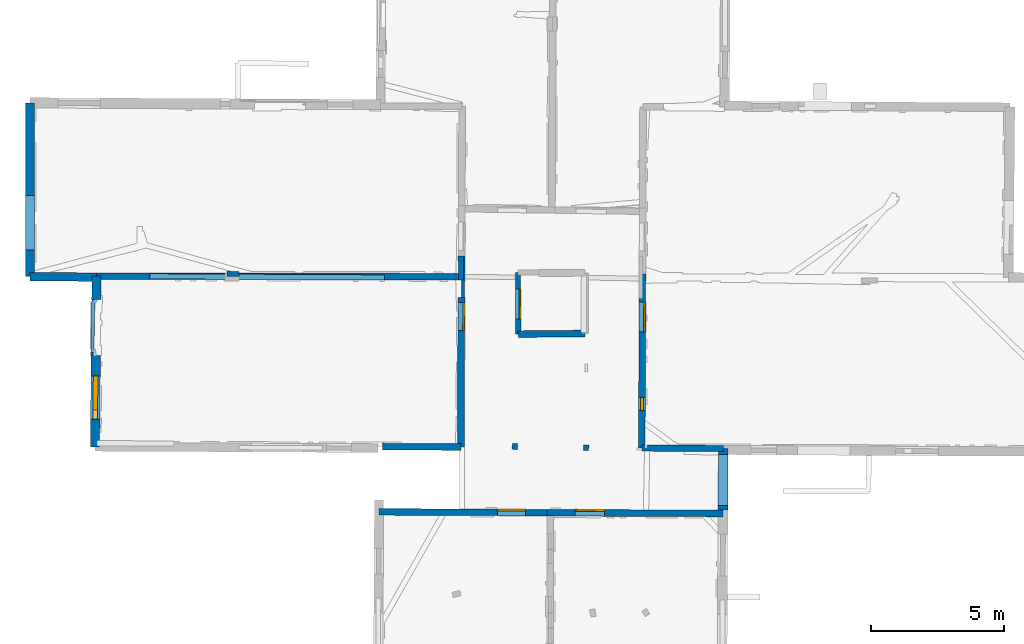
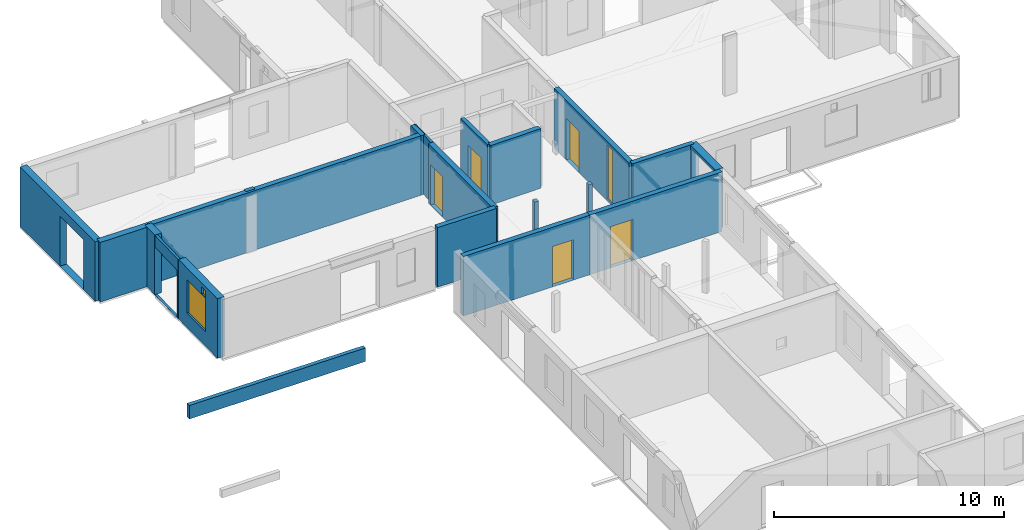
# One storey, part 8 of 17: 21 walls, 5 doors, 3 windows, 11 openings.
"""IFC2X3 building model written with IfcOpenShell, lengths in metres."""

from ifc_helpers import new_model, entity, si_unit, converted_unit, derived_unit, direction, frame, frame_2d, origin, origin_2d_with_axis, place, context, subcontext, project, spatial, polyline, rectangle, outline, extrude, source, transform, mapped, material, layer, layer_set, layer_usage, type_object, type_shapes, element, fill, save


model = new_model("IFC2X3")

# Units and contexts
model_context = context("Model", 3, precision=1e-05, world=origin(), true_north=direction((0.0, 1.0)))
body_context = subcontext(model_context, "Body", "Model", "MODEL_VIEW")
ifc_project = project(units=[si_unit("LENGTHUNIT", "METRE"), si_unit("AREAUNIT", "SQUARE_METRE"), si_unit("VOLUMEUNIT", "CUBIC_METRE"), converted_unit("PLANEANGLEUNIT", "DEGREE", entity("IfcRatioMeasure", 0.0174532925199433), si_unit("PLANEANGLEUNIT", "RADIAN"), dimensions=[0, 0, 0, 0, 0, 0, 0]), si_unit("MASSUNIT", "GRAM", prefix="KILO"), derived_unit("MASSDENSITYUNIT", [(si_unit("MASSUNIT", "GRAM", prefix="KILO"), 1), (si_unit("LENGTHUNIT", "METRE"), -3)]), derived_unit("MOMENTOFINERTIAUNIT", [(si_unit("LENGTHUNIT", "METRE"), 4)]), si_unit("TIMEUNIT", "SECOND"), si_unit("FREQUENCYUNIT", "HERTZ"), si_unit("THERMODYNAMICTEMPERATUREUNIT", "DEGREE_CELSIUS"), derived_unit("THERMALTRANSMITTANCEUNIT", [(si_unit("MASSUNIT", "GRAM", prefix="KILO"), 1), (si_unit("THERMODYNAMICTEMPERATUREUNIT", "KELVIN"), -1), (si_unit("TIMEUNIT", "SECOND"), -3)]), derived_unit("VOLUMETRICFLOWRATEUNIT", [(si_unit("LENGTHUNIT", "METRE"), 3), (si_unit("TIMEUNIT", "SECOND"), -1)]), si_unit("ELECTRICCURRENTUNIT", "AMPERE"), si_unit("ELECTRICVOLTAGEUNIT", "VOLT"), si_unit("POWERUNIT", "WATT"), si_unit("FORCEUNIT", "NEWTON", prefix="KILO"), si_unit("ILLUMINANCEUNIT", "LUX"), si_unit("LUMINOUSFLUXUNIT", "LUMEN"), si_unit("LUMINOUSINTENSITYUNIT", "CANDELA"), derived_unit("USERDEFINED", [(si_unit("MASSUNIT", "GRAM", prefix="KILO"), -1), (si_unit("LENGTHUNIT", "METRE"), -2), (si_unit("TIMEUNIT", "SECOND"), 3), (si_unit("LUMINOUSFLUXUNIT", "LUMEN"), 1)]), derived_unit("LINEARVELOCITYUNIT", [(si_unit("LENGTHUNIT", "METRE"), 1), (si_unit("TIMEUNIT", "SECOND"), -1)]), si_unit("PRESSUREUNIT", "PASCAL"), derived_unit("USERDEFINED", [(si_unit("LENGTHUNIT", "METRE"), -2), (si_unit("MASSUNIT", "GRAM", prefix="KILO"), 1), (si_unit("TIMEUNIT", "SECOND"), -2)]), derived_unit("LINEARFORCEUNIT", [(si_unit("MASSUNIT", "GRAM", prefix="KILO"), 1), (si_unit("LENGTHUNIT", "METRE"), 1), (si_unit("TIMEUNIT", "SECOND"), -2), (si_unit("LENGTHUNIT", "METRE"), -1)]), derived_unit("PLANARFORCEUNIT", [(si_unit("MASSUNIT", "GRAM", prefix="KILO"), 1), (si_unit("LENGTHUNIT", "METRE"), 1), (si_unit("TIMEUNIT", "SECOND"), -2), (si_unit("LENGTHUNIT", "METRE"), -2)])], contexts=[model_context])

# Site, building, storey
placement_1 = place(None, origin())
site = spatial("IfcSite", under=ifc_project, at=placement_1, CompositionType="ELEMENT")
building = spatial("IfcBuilding", under=site, at=placement_1, CompositionType="ELEMENT")
storey_placement = place(placement_1, frame((0.0, 0.0, 5.56662893295288)))
storey = spatial("IfcBuildingStorey", under=building, at=storey_placement, Name="Level 3", CompositionType="ELEMENT", Elevation=5.56662893295288)

# Wall, openings, door, window
ifc_material_1 = material(Name="Default wall")
ifc_layer_1 = layer(ifc_material_1, 0.25)
ifc_layer_set_1 = layer_set([ifc_layer_1], Name="wall_thickness_0.2500")
ifc_layer_usage_1 = layer_usage(ifc_layer_set_1, "AXIS2", "POSITIVE", -0.125)
wall_type_1 = type_object("IfcWallType", Name="wall_thickness_0.2500", PredefinedType="STANDARD", material=ifc_layer_set_1)
wall_1_placement = place(storey_placement, frame((9.78111944718511, 57.7562444193893, 0.0), z_axis=(0.0, 0.0, 1.0), x_axis=(-0.00369449240200156, -0.999993175339658, 0.0)))
wall_1 = element("IfcWallStandardCase", 1, at=wall_1_placement, inside=storey, type_object=wall_type_1, material=ifc_layer_usage_1, Name="Wall:3", ObjectType="Wall", context=body_context, shape_type="SweptSolid", body=[
    extrude(outline(polyline([(6.56744670657942, -0.125), (6.56744670657942, 0.125), (0.0, 0.125), (0.0, -0.125), (6.56744670657942, -0.125)])), origin(), (0.0, 0.0, 1.0), 3.16489877700806),
])
opening_1_placement = place(wall_1_placement, frame((1.07119718488194, -0.125, 0.00537109375)))
opening_1 = element("IfcOpeningElement", 2, at=opening_1_placement, cuts=wall_1, Name="Opening : 1115 x 2200 : 1", ObjectType="Opening", context=body_context, shape_type="SweptSolid", body=[
    extrude(rectangle(XDim=1.115, YDim=2.2, at=frame_2d((1.1, 0.5575), x_axis=(0.0, 1.0))), frame((0.0, 0.0, 0.0), z_axis=(0.0, 1.0, 0.0), x_axis=(0.0, 0.0, 1.0)), (0.0, 0.0, 1.0), 0.25),
])
opening_2_placement = place(wall_1_placement, frame((4.65531283281122, -0.125, 0.13637113571167)))
opening_2 = element("IfcOpeningElement", 3, at=opening_2_placement, cuts=wall_1, Name="Opening : 490 x 2840 : 2", ObjectType="Opening", context=body_context, shape_type="SweptSolid", body=[
    extrude(rectangle(XDim=0.49, YDim=2.84, at=frame_2d((1.42, 0.245), x_axis=(0.0, 1.0))), frame((0.0, 0.0, 0.0), z_axis=(0.0, 1.0, 0.0), x_axis=(0.0, 0.0, 1.0)), (0.0, 0.0, 1.0), 0.25),
])
ifc_material_2 = material(Name="Door Panel")
door_style_1 = type_object("IfcDoorStyle", Name="Door : 1115 x 2200mm", ConstructionType="NOTDEFINED", OperationType="SINGLE_SWING_RIGHT", ParameterTakesPrecedence=False, Sizeable=False, material=ifc_material_2)
shared_shape_1 = source(origin(), body_context, "Body", "SweptSolid", [
    extrude(rectangle(XDim=0.0625, YDim=1.115, at=origin_2d_with_axis()), frame((0.5575, 0.21875, 0.0), z_axis=(0.0, 0.0, 1.0), x_axis=(0.0, 1.0, 0.0)), (0.0, 0.0, 1.0), 2.2),
])
type_shapes(door_style_1, [shared_shape_1])
door_1_placement = place(opening_1_placement, origin())
door_1 = element("IfcDoor", 4, at=door_1_placement, inside=storey, type_object=door_style_1, Name="Door : 1115 x 2200mm : 1", ObjectType="Door : 1115 x 2200mm", OverallHeight=2.2, OverallWidth=1.115, context=body_context, shape_type="MappedRepresentation", body=[
    mapped(shared_shape_1, transform((0.0, 0.0, 0.0), scale=1.0)),
])
fill(opening_1, door_1)
ifc_material_3 = material(Name="Window Default")
window_style_1 = type_object("IfcWindowStyle", Name="Window : 490 x 2840mm", ConstructionType="NOTDEFINED", OperationType="NOTDEFINED", ParameterTakesPrecedence=False, Sizeable=False, material=ifc_material_3)
shared_shape_2 = source(origin(), body_context, "Body", "SweptSolid", [
    extrude(rectangle(XDim=0.125, YDim=0.49, at=origin_2d_with_axis()), frame((0.245, 0.125, 0.0), z_axis=(0.0, 0.0, 1.0), x_axis=(0.0, 1.0, 0.0)), (0.0, 0.0, 1.0), 2.84),
])
type_shapes(window_style_1, [shared_shape_2])
window_1_placement = place(opening_2_placement, origin())
window_1 = element("IfcWindow", 5, at=window_1_placement, inside=storey, type_object=window_style_1, Name="Window : 490 x 2840mm : 0", ObjectType="Window : 490 x 2840mm", OverallHeight=2.84, OverallWidth=0.49, context=body_context, shape_type="MappedRepresentation", body=[
    mapped(shared_shape_2, transform((0.0, 0.0, 0.0), scale=1.0)),
])
fill(opening_2, window_1)

# Walls
wall_2_placement = place(storey_placement, frame((5.0986576600224, 55.4807384582238, 0.0), z_axis=(0.0, 0.0, 1.0), x_axis=(0.999948029186629, 0.0101950441772794, 0.0)))
element("IfcWallStandardCase", 6, at=wall_2_placement, inside=storey, type_object=wall_type_1, material=ifc_layer_usage_1, Name="Wall:27", ObjectType="Wall", context=body_context, shape_type="SweptSolid", body=[
    extrude(outline(polyline([(2.52116908262779, -0.125), (2.52116908262779, 0.125), (0.0, 0.125), (0.0, -0.125), (2.52116908262779, -0.125)])), origin(), (0.0, 0.0, 1.0), 3.16489877700806),
])
wall_3_placement = place(storey_placement, frame((-0.0209414552045773, 51.2428181533648, 0.0), z_axis=(0.0, 0.0, 1.0), x_axis=(0.999979305969106, -0.00643332212352179, 0.0)))
element("IfcWallStandardCase", 7, at=wall_3_placement, inside=storey, type_object=wall_type_1, material=ifc_layer_usage_1, Name="Wall:45", ObjectType="Wall", context=body_context, shape_type="SweptSolid", body=[
    extrude(outline(polyline([(2.95649435877992, -0.125), (2.95649435877992, 0.125), (0.0, 0.125), (0.0, -0.125), (2.95649435877992, -0.125)])), origin(), (0.0, 0.0, 1.0), 3.16489877700806),
])

# Wall, opening, door
wall_4_placement = place(storey_placement, frame((-0.150655875965148, 48.7811713381954, 0.0), z_axis=(0.0, 0.0, 1.0), x_axis=(0.999988424161903, -0.00481160494982628, 0.0)))
wall_4 = element("IfcWallStandardCase", 8, at=wall_4_placement, inside=storey, type_object=wall_type_1, material=ifc_layer_usage_1, Name="Wall:79", ObjectType="Wall", context=body_context, shape_type="SweptSolid", body=[
    extrude(outline(polyline([(6.33853048134657, -0.125), (6.33853048134657, 0.125), (0.0, 0.125), (0.0, -0.125), (6.33853048134657, -0.125)])), origin(), (0.0, 0.0, 1.0), 3.16489877700806),
])
opening_3_placement = place(wall_4_placement, frame((4.46256507927795, -0.125, 0.00537109375)))
opening_3 = element("IfcOpeningElement", 9, at=opening_3_placement, cuts=wall_4, Name="Opening : 1060 x 2140 : 75", ObjectType="Opening", context=body_context, shape_type="SweptSolid", body=[
    extrude(rectangle(XDim=1.06, YDim=2.14, at=frame_2d((1.07, 0.53), x_axis=(0.0, 1.0))), frame((0.0, 0.0, 0.0), z_axis=(0.0, 1.0, 0.0), x_axis=(0.0, 0.0, 1.0)), (0.0, 0.0, 1.0), 0.25),
])
door_style_2 = type_object("IfcDoorStyle", Name="Door : 1060 x 2140mm", ConstructionType="NOTDEFINED", OperationType="SINGLE_SWING_RIGHT", ParameterTakesPrecedence=False, Sizeable=False, material=ifc_material_2)
shared_shape_3 = source(origin(), body_context, "Body", "SweptSolid", [
    extrude(rectangle(XDim=0.0625, YDim=1.06, at=origin_2d_with_axis()), frame((0.53, 0.21875, 0.0), z_axis=(0.0, 0.0, 1.0), x_axis=(0.0, 1.0, 0.0)), (0.0, 0.0, 1.0), 2.14),
])
type_shapes(door_style_2, [shared_shape_3])
door_2_placement = place(opening_3_placement, origin())
door_2 = element("IfcDoor", 10, at=door_2_placement, inside=storey, type_object=door_style_2, Name="Door : 1060 x 2140mm : 9", ObjectType="Door : 1060 x 2140mm", OverallHeight=2.14, OverallWidth=1.06, context=body_context, shape_type="MappedRepresentation", body=[
    mapped(shared_shape_3, transform((0.0, 0.0, 0.0), scale=1.0)),
])
fill(opening_3, door_2)

wall_5_placement = place(storey_placement, frame((6.1878012315788, 48.7506728335568, 0.0), z_axis=(0.0, 0.0, 1.0), x_axis=(0.99998842424609, -0.00481158745341919, 0.0)))
wall_5 = element("IfcWallStandardCase", 11, at=wall_5_placement, inside=storey, type_object=wall_type_1, material=ifc_layer_usage_1, Name="Wall:80", ObjectType="Wall", context=body_context, shape_type="SweptSolid", body=[
    extrude(outline(polyline([(6.62713808115447, -0.125), (6.62713808115447, 0.125), (0.0, 0.125), (0.0, -0.125), (6.62713808115447, -0.125)])), origin(), (0.0, 0.0, 1.0), 3.16489877700806),
])
opening_4_placement = place(wall_5_placement, frame((1.04903431056386, -0.125, 0.00537109375)))
opening_4 = element("IfcOpeningElement", 12, at=opening_4_placement, cuts=wall_5, Name="Opening : 1115 x 2185 : 76", ObjectType="Opening", context=body_context, shape_type="SweptSolid", body=[
    extrude(rectangle(XDim=1.115, YDim=2.185, at=frame_2d((1.0925, 0.5575), x_axis=(0.0, 1.0))), frame((0.0, 0.0, 0.0), z_axis=(0.0, 1.0, 0.0), x_axis=(0.0, 0.0, 1.0)), (0.0, 0.0, 1.0), 0.25),
])
door_style_3 = type_object("IfcDoorStyle", Name="Door : 1115 x 2185mm", ConstructionType="NOTDEFINED", OperationType="SINGLE_SWING_RIGHT", ParameterTakesPrecedence=False, Sizeable=False, material=ifc_material_2)
shared_shape_4 = source(origin(), body_context, "Body", "SweptSolid", [
    extrude(rectangle(XDim=0.0625, YDim=1.115, at=origin_2d_with_axis()), frame((0.5575, 0.21875, 0.0), z_axis=(0.0, 0.0, 1.0), x_axis=(0.0, 1.0, 0.0)), (0.0, 0.0, 1.0), 2.185),
])
type_shapes(door_style_3, [shared_shape_4])
door_3_placement = place(opening_4_placement, origin())
door_3 = element("IfcDoor", 13, at=door_3_placement, inside=storey, type_object=door_style_3, Name="Door : 1115 x 2185mm : 10", ObjectType="Door : 1115 x 2185mm", OverallHeight=2.185, OverallWidth=1.115, context=body_context, shape_type="MappedRepresentation", body=[
    mapped(shared_shape_4, transform((0.0, 0.0, 0.0), scale=1.0)),
])
fill(opening_4, door_3)

# Walls
wall_6_placement = place(storey_placement, frame((-10.7945720015035, 57.6681822203561, 0.0), z_axis=(0.0, 0.0, 1.0), x_axis=(0.999998779339919, -0.00156247197478348, 0.0)))
element("IfcWallStandardCase", 14, at=wall_6_placement, inside=storey, type_object=wall_type_1, material=ifc_layer_usage_1, Name="Wall:90", ObjectType="Wall", context=body_context, shape_type="SweptSolid", body=[
    extrude(outline(polyline([(13.7355979260878, -0.125), (13.7355979260878, 0.125), (0.0, 0.125), (0.0, -0.125), (13.7355979260878, -0.125)])), origin(), (0.0, 0.0, 1.0), 3.16489877700806),
])
ifc_layer_2 = layer(ifc_material_1, 0.349999994039536)
ifc_layer_set_2 = layer_set([ifc_layer_2], Name="wall_thickness_0.3500")
ifc_layer_usage_2 = layer_usage(ifc_layer_set_2, "AXIS2", "POSITIVE", -0.174999997019768)
wall_type_2 = type_object("IfcWallType", Name="wall_thickness_0.3500", PredefinedType="STANDARD", material=ifc_layer_set_2)
wall_7_placement = place(storey_placement, frame((-10.7945718460724, 57.6681847496013, 0.0), z_axis=(0.0, 0.0, 1.0), x_axis=(-0.00977348901655846, -0.999952238315632, 0.0)))
element("IfcWallStandardCase", 15, at=wall_7_placement, inside=storey, type_object=wall_type_2, material=ifc_layer_usage_2, Name="Wall:43", ObjectType="Wall", context=body_context, shape_type="SweptSolid", body=[
    extrude(outline(polyline([(0.889908378767243, -0.174999997019768), (0.889908378767243, 0.174999997019768), (0.0, 0.174999997019768), (0.0, -0.174999997019768), (0.889908378767243, -0.174999997019768)])), origin(), (0.0, 0.0, 1.0), 3.16489877700806),
])

# Wall, openings, windows
wall_8_placement = place(storey_placement, frame((-10.8238362976345, 54.6742232630607, 0.0), z_axis=(0.0, 0.0, 1.0), x_axis=(-0.00977437911464313, -0.999952229615457, 0.0)))
wall_8 = element("IfcWallStandardCase", 16, at=wall_8_placement, inside=storey, type_object=wall_type_2, material=ifc_layer_usage_2, Name="Wall:44", ObjectType="Wall", context=body_context, shape_type="SweptSolid", body=[
    extrude(outline(polyline([(3.4422268144283, -0.174999997019768), (3.4422268144283, 0.174999997019768), (0.0, 0.174999997019768), (0.0, -0.174999997019768), (3.4422268144283, -0.174999997019768)])), origin(), (0.0, 0.0, 1.0), 3.16489877700806),
])
opening_5_placement = place(wall_8_placement, frame((2.04613345090446, -0.174999997019768, 2.57737112045288)))
opening_5 = element("IfcOpeningElement", 17, at=opening_5_placement, cuts=wall_8, Name="Opening : 355 x 380 : 34", ObjectType="Opening", context=body_context, shape_type="SweptSolid", body=[
    extrude(rectangle(XDim=0.355, YDim=0.38, at=frame_2d((0.19, 0.1775), x_axis=(0.0, 1.0))), frame((0.0, 0.0, 0.0), z_axis=(0.0, 1.0, 0.0), x_axis=(0.0, 0.0, 1.0)), (0.0, 0.0, 1.0), 0.349999994039536),
])
opening_6_placement = place(wall_8_placement, frame((0.77229177467595, -0.174999997019768, 0.775371074676514)))
opening_6 = element("IfcOpeningElement", 18, at=opening_6_placement, cuts=wall_8, Name="Opening : 1635 x 1780 : 35", ObjectType="Opening", context=body_context, shape_type="SweptSolid", body=[
    extrude(rectangle(XDim=1.635, YDim=1.78, at=frame_2d((0.89, 0.8175), x_axis=(0.0, 1.0))), frame((0.0, 0.0, 0.0), z_axis=(0.0, 1.0, 0.0), x_axis=(0.0, 0.0, 1.0)), (0.0, 0.0, 1.0), 0.349999994039536),
])
window_style_2 = type_object("IfcWindowStyle", Name="Window : 355 x 380mm", ConstructionType="NOTDEFINED", OperationType="NOTDEFINED", ParameterTakesPrecedence=False, Sizeable=False, material=ifc_material_3)
shared_shape_5 = source(origin(), body_context, "Body", "SweptSolid", [
    extrude(rectangle(XDim=0.174999997019768, YDim=0.355, at=origin_2d_with_axis()), frame((0.1775, 0.174999997019768, 0.0), z_axis=(0.0, 0.0, 1.0), x_axis=(0.0, 1.0, 0.0)), (0.0, 0.0, 1.0), 0.38),
])
type_shapes(window_style_2, [shared_shape_5])
window_2_placement = place(opening_5_placement, origin())
window_2 = element("IfcWindow", 19, at=window_2_placement, inside=storey, type_object=window_style_2, Name="Window : 355 x 380mm : 17", ObjectType="Window : 355 x 380mm", OverallHeight=0.38, OverallWidth=0.355, context=body_context, shape_type="MappedRepresentation", body=[
    mapped(shared_shape_5, transform((0.0, 0.0, 0.0), scale=1.0)),
])
fill(opening_5, window_2)
window_style_3 = type_object("IfcWindowStyle", Name="Window : 1635 x 1780mm", ConstructionType="NOTDEFINED", OperationType="NOTDEFINED", ParameterTakesPrecedence=False, Sizeable=False, material=ifc_material_3)
shared_shape_6 = source(origin(), body_context, "Body", "SweptSolid", [
    extrude(rectangle(XDim=0.174999997019768, YDim=1.635, at=origin_2d_with_axis()), frame((0.8175, 0.174999997019768, 0.0), z_axis=(0.0, 0.0, 1.0), x_axis=(0.0, 1.0, 0.0)), (0.0, 0.0, 1.0), 1.78),
])
type_shapes(window_style_3, [shared_shape_6])
window_3_placement = place(opening_6_placement, origin())
window_3 = element("IfcWindow", 20, at=window_3_placement, inside=storey, type_object=window_style_3, Name="Window : 1635 x 1780mm : 18", ObjectType="Window : 1635 x 1780mm", OverallHeight=1.78, OverallWidth=1.635, context=body_context, shape_type="MappedRepresentation", body=[
    mapped(shared_shape_6, transform((0.0, 0.0, 0.0), scale=1.0)),
])
fill(opening_6, window_3)

# Wall
ifc_layer_3 = layer(ifc_material_1, 0.2)
ifc_layer_set_3 = layer_set([ifc_layer_3], Name="wall_thickness_0.2000")
ifc_layer_usage_3 = layer_usage(ifc_layer_set_3, "AXIS2", "POSITIVE", -0.1)
wall_type_3 = type_object("IfcWallType", Name="wall_thickness_0.2000", PredefinedType="STANDARD", material=ifc_layer_set_3)
wall_9_placement = place(storey_placement, frame((7.65870206376349, 51.3060151050902, 0.0), z_axis=(0.0, 0.0, 1.0), x_axis=(-0.0179651972689874, -0.999838612820632, 0.0)))
element("IfcWallStandardCase", 21, at=wall_9_placement, inside=storey, type_object=wall_type_3, material=ifc_layer_usage_3, Name="Wall:11", ObjectType="Wall", context=body_context, shape_type="SweptSolid", body=[
    extrude(outline(polyline([(0.210002458598985, -0.1), (0.210002458598985, 0.1), (0.0, 0.1), (0.0, -0.1), (0.210002458598985, -0.1)])), origin(), (0.0, 0.0, 1.0), 2.79037141799927),
])

# Wall, opening, door
wall_10_placement = place(storey_placement, frame((5.08639348373931, 57.7998147465092, 0.0), z_axis=(0.0, 0.0, 1.0), x_axis=(0.00528833776667934, -0.999986016644066, 0.0)))
wall_10 = element("IfcWallStandardCase", 22, at=wall_10_placement, inside=storey, type_object=wall_type_3, material=ifc_layer_usage_3, Name="Wall:22", ObjectType="Wall", context=body_context, shape_type="SweptSolid", body=[
    extrude(outline(polyline([(2.31911278176268, -0.1), (2.31911278176268, 0.1), (0.0, 0.1), (0.0, -0.1), (2.31911278176268, -0.1)])), origin(), (0.0, 0.0, 1.0), 3.16489877700806),
])
opening_7_placement = place(wall_10_placement, frame((0.620755313184593, -0.1, 0.00537109375)))
opening_7 = element("IfcOpeningElement", 23, at=opening_7_placement, cuts=wall_10, Name="Opening : 1135 x 2125 : 23", ObjectType="Opening", context=body_context, shape_type="SweptSolid", body=[
    extrude(rectangle(XDim=1.135, YDim=2.125, at=frame_2d((1.0625, 0.5675), x_axis=(0.0, 1.0))), frame((0.0, 0.0, 0.0), z_axis=(0.0, 1.0, 0.0), x_axis=(0.0, 0.0, 1.0)), (0.0, 0.0, 1.0), 0.2),
])
door_style_4 = type_object("IfcDoorStyle", Name="Door : 1135 x 2125mm", ConstructionType="NOTDEFINED", OperationType="SINGLE_SWING_RIGHT", ParameterTakesPrecedence=False, Sizeable=False, material=ifc_material_2)
shared_shape_7 = source(origin(), body_context, "Body", "SweptSolid", [
    extrude(rectangle(XDim=0.05, YDim=1.135, at=origin_2d_with_axis()), frame((0.5675, 0.175, 0.0), z_axis=(0.0, 0.0, 1.0), x_axis=(0.0, 1.0, 0.0)), (0.0, 0.0, 1.0), 2.125),
])
type_shapes(door_style_4, [shared_shape_7])
door_4_placement = place(opening_7_placement, origin())
door_4 = element("IfcDoor", 24, at=door_4_placement, inside=storey, type_object=door_style_4, Name="Door : 1135 x 2125mm : 4", ObjectType="Door : 1135 x 2125mm", OverallHeight=2.125, OverallWidth=1.135, context=body_context, shape_type="MappedRepresentation", body=[
    mapped(shared_shape_7, transform((0.0, 0.0, 0.0), scale=1.0)),
])
fill(opening_7, door_4)

# Walls
wall_11_placement = place(storey_placement, frame((4.96644398060751, 51.1379237699774, 0.0), z_axis=(0.0, 0.0, 1.0), x_axis=(0.0552325746197171, 0.998473516274156, 0.0)))
element("IfcWallStandardCase", 25, at=wall_11_placement, inside=storey, type_object=wall_type_3, material=ifc_layer_usage_3, Name="Wall:83", ObjectType="Wall", context=body_context, shape_type="SweptSolid", body=[
    extrude(outline(polyline([(0.220001355833093, -0.1), (0.220001355833093, 0.1), (0.0, 0.1), (0.0, -0.1), (0.220001355833093, -0.1)])), origin(), (0.0, 0.0, 1.0), 2.79037141799927),
])
wall_12_placement = place(storey_placement, frame((-5.87901607740577, 57.7536579366894, 0.0), z_axis=(0.0, 0.0, 1.0), x_axis=(0.999797413768482, -0.0201278767348884, 0.0)))
element("IfcWallStandardCase", 26, at=wall_12_placement, inside=storey, type_object=wall_type_3, material=ifc_layer_usage_3, Name="Wall:104", ObjectType="Wall", context=body_context, shape_type="SweptSolid", body=[
    extrude(outline(polyline([(0.445000200352091, -0.1), (0.445000200352091, 0.1), (0.0, 0.1), (0.0, -0.1), (0.445000200352091, -0.1)])), origin(), (0.0, 0.0, 1.0), 3.16489877700806),
])
placement_2 = place(placement_1, frame((0.0, 0.0, -2.2819995880127)))
wall_13_placement = place(placement_2, frame((-8.79092654897152, 57.6600000304731, 0.0), z_axis=(0.0, 0.0, 1.0), x_axis=(0.999986571818242, -0.00518229516716474, 0.0)))
element("IfcWallStandardCase", 27, at=wall_13_placement, inside=storey, type_object=wall_type_3, material=ifc_layer_usage_3, Name="Wall:845", ObjectType="Wall", context=body_context, shape_type="SweptSolid", body=[
    extrude(outline(polyline([(8.84500030684818, -0.1), (8.84500030684818, 0.1), (0.0, 0.1), (0.0, -0.1), (8.84500030684818, -0.1)])), origin(), (0.0, 0.0, 1.0), 0.720746183395386),
])
ifc_layer_4 = layer(ifc_material_1, 0.239999994635582)
ifc_layer_set_4 = layer_set([ifc_layer_4], Name="wall_thickness_0.2400")
ifc_layer_usage_4 = layer_usage(ifc_layer_set_4, "AXIS2", "POSITIVE", -0.119999997317791)
wall_type_4 = type_object("IfcWallType", Name="wall_thickness_0.2400", PredefinedType="STANDARD", material=ifc_layer_set_4)
wall_14_placement = place(storey_placement, frame((9.75685593013865, 51.1888446789835, 0.0), z_axis=(0.0, 0.0, 1.0), x_axis=(0.999975201651589, -0.00704244857019553, 0.0)))
element("IfcWallStandardCase", 28, at=wall_14_placement, inside=storey, type_object=wall_type_4, material=ifc_layer_usage_4, Name="Wall:7", ObjectType="Wall", context=body_context, shape_type="SweptSolid", body=[
    extrude(outline(polyline([(3.07019694727599, -0.119999997317791), (3.07019694727599, 0.119999997317791), (0.0, 0.119999997317791), (0.0, -0.119999997317791), (3.07019694727599, -0.119999997317791)])), origin(), (0.0, 0.0, 1.0), 3.16489877700806),
])

# Wall, opening, door
ifc_layer_5 = layer(ifc_material_1, 0.259999990463257)
ifc_layer_set_5 = layer_set([ifc_layer_5], Name="wall_thickness_0.2600")
ifc_layer_usage_5 = layer_usage(ifc_layer_set_5, "AXIS2", "POSITIVE", -0.129999995231628)
wall_type_5 = type_object("IfcWallType", Name="wall_thickness_0.2600", PredefinedType="STANDARD", material=ifc_layer_set_5)
wall_15_placement = place(storey_placement, frame((2.95476357813292, 56.8534189575341, 0.0), z_axis=(0.0, 0.0, 1.0), x_axis=(-0.00342331764012925, -0.999994140431, 0.0)))
wall_15 = element("IfcWallStandardCase", 29, at=wall_15_placement, inside=storey, type_object=wall_type_5, material=ifc_layer_usage_5, Name="Wall:10", ObjectType="Wall", context=body_context, shape_type="SweptSolid", body=[
    extrude(outline(polyline([(5.62965258572644, -0.129999995231628), (5.62965258572644, 0.129999995231628), (0.0, 0.129999995231628), (0.0, -0.129999995231628), (5.62965258572644, -0.129999995231628)])), origin(), (0.0, 0.0, 1.0), 3.16489877700806),
])
opening_8_placement = place(wall_15_placement, frame((0.182553396267934, -0.129999995231628, 0.00537109375)))
opening_8 = element("IfcOpeningElement", 30, at=opening_8_placement, cuts=wall_15, Name="Opening : 1055 x 2140 : 8", ObjectType="Opening", context=body_context, shape_type="SweptSolid", body=[
    extrude(rectangle(XDim=1.055, YDim=2.14, at=frame_2d((1.07, 0.5275), x_axis=(0.0, 1.0))), frame((0.0, 0.0, 0.0), z_axis=(0.0, 1.0, 0.0), x_axis=(0.0, 0.0, 1.0)), (0.0, 0.0, 1.0), 0.259999990463257),
])
door_style_5 = type_object("IfcDoorStyle", Name="Door : 1055 x 2140mm", ConstructionType="NOTDEFINED", OperationType="SINGLE_SWING_RIGHT", ParameterTakesPrecedence=False, Sizeable=False, material=ifc_material_2)
shared_shape_8 = source(origin(), body_context, "Body", "SweptSolid", [
    extrude(rectangle(XDim=0.0649999976158142, YDim=1.055, at=origin_2d_with_axis()), frame((0.5275, 0.22749999165535, 0.0), z_axis=(0.0, 0.0, 1.0), x_axis=(0.0, 1.0, 0.0)), (0.0, 0.0, 1.0), 2.14),
])
type_shapes(door_style_5, [shared_shape_8])
door_5_placement = place(opening_8_placement, origin())
door_5 = element("IfcDoor", 31, at=door_5_placement, inside=storey, type_object=door_style_5, Name="Door : 1055 x 2140mm : 3", ObjectType="Door : 1055 x 2140mm", OverallHeight=2.14, OverallWidth=1.055, context=body_context, shape_type="MappedRepresentation", body=[
    mapped(shared_shape_8, transform((0.0, 0.0, 0.0), scale=1.0)),
])
fill(opening_8, door_5)

# Wall, opening
ifc_layer_6 = layer(ifc_material_1, 0.119999997317791)
ifc_layer_set_6 = layer_set([ifc_layer_6], Name="wall_thickness_0.1200")
ifc_layer_usage_6 = layer_usage(ifc_layer_set_6, "AXIS2", "POSITIVE", -0.0599999986588955)
wall_type_6 = type_object("IfcWallType", Name="wall_thickness_0.1200", PredefinedType="STANDARD", material=ifc_layer_set_6)
wall_16_placement = place(storey_placement, frame((-10.9157345870945, 56.7787946531193, 0.0), z_axis=(0.0, 0.0, 1.0), x_axis=(-0.019731246382787, -0.999805320007941, 0.0)))
wall_16 = element("IfcWallStandardCase", 32, at=wall_16_placement, inside=storey, type_object=wall_type_6, material=ifc_layer_usage_6, Name="Wall:17", ObjectType="Wall", context=body_context, shape_type="SweptSolid", body=[
    extrude(outline(polyline([(2.10408928106695, -0.0599999986588955), (2.10408928106695, 0.0599999986588955), (0.0, 0.0599999986588955), (0.0, -0.0599999986588955), (2.10408928106695, -0.0599999986588955)])), origin(), (0.0, 0.0, 1.0), 3.16489877700806),
])
opening_9_placement = place(wall_16_placement, frame((-0.00351019353385252, -0.0599999986588955, 0.00537109375)))
element("IfcOpeningElement", 33, at=opening_9_placement, cuts=wall_16, Name="Opening : 2000 x 2535 : 18", ObjectType="Opening", context=body_context, shape_type="SweptSolid", body=[
    extrude(rectangle(XDim=2.0, YDim=2.535, at=frame_2d((1.2675, 1.0), x_axis=(0.0, 1.0))), frame((0.0, 0.0, 0.0), z_axis=(0.0, 1.0, 0.0), x_axis=(0.0, 0.0, 1.0)), (0.0, 0.0, 1.0), 0.119999997317791),
])

# Wall
wall_17_placement = place(storey_placement, frame((3.03631670307245, 58.4261709885711, 0.0), z_axis=(0.0, 0.0, 1.0), x_axis=(-0.0143579743144761, -0.999896918973943, 0.0)))
element("IfcWallStandardCase", 34, at=wall_17_placement, inside=storey, type_object=wall_type_6, material=ifc_layer_usage_6, Name="Wall:88", ObjectType="Wall", context=body_context, shape_type="SweptSolid", body=[
    extrude(outline(polyline([(1.57233996537983, -0.0599999986588955), (1.57233996537983, 0.0599999986588955), (0.0, 0.0599999986588955), (0.0, -0.0599999986588955), (1.57233996537983, -0.0599999986588955)])), origin(), (0.0, 0.0, 1.0), 3.16489877700806),
])

# Wall, opening
ifc_layer_7 = layer(ifc_material_1, 0.340000003576279)
ifc_layer_set_7 = layer_set([ifc_layer_7], Name="wall_thickness_0.3400")
ifc_layer_usage_7 = layer_usage(ifc_layer_set_7, "AXIS2", "POSITIVE", -0.170000001788139)
wall_type_7 = type_object("IfcWallType", Name="wall_thickness_0.3400", PredefinedType="STANDARD", material=ifc_layer_set_7)
wall_18_placement = place(storey_placement, frame((-13.2971281977453, 64.1996360055563, 0.0), z_axis=(0.0, 0.0, 1.0), x_axis=(-0.00216799119458811, -0.999997649904329, 0.0)))
wall_18 = element("IfcWallStandardCase", 35, at=wall_18_placement, inside=storey, type_object=wall_type_7, material=ifc_layer_usage_7, Name="Wall:42", ObjectType="Wall", context=body_context, shape_type="SweptSolid", body=[
    extrude(outline(polyline([(6.55521788952005, -0.170000001788139), (6.55521788952005, 0.170000001788139), (0.0, 0.170000001788139), (0.0, -0.170000001788139), (6.55521788952005, -0.170000001788139)])), origin(), (0.0, 0.0, 1.0), 3.16489877700806),
])
opening_10_placement = place(wall_18_placement, frame((3.48955591501393, -0.170000001788139, 0.00537109375)))
element("IfcOpeningElement", 36, at=opening_10_placement, cuts=wall_18, Name="Opening : 2060 x 2655 : 33", ObjectType="Opening", context=body_context, shape_type="SweptSolid", body=[
    extrude(rectangle(XDim=2.06, YDim=2.655, at=frame_2d((1.3275, 1.03), x_axis=(0.0, 1.0))), frame((0.0, 0.0, 0.0), z_axis=(0.0, 1.0, 0.0), x_axis=(0.0, 0.0, 1.0)), (0.0, 0.0, 1.0), 0.340000003576279),
])

ifc_layer_8 = layer(ifc_material_1, 0.370000004768372)
ifc_layer_set_8 = layer_set([ifc_layer_8], Name="wall_thickness_0.3700")
ifc_layer_usage_8 = layer_usage(ifc_layer_set_8, "AXIS2", "POSITIVE", -0.185000002384186)
wall_type_8 = type_object("IfcWallType", Name="wall_thickness_0.3700", PredefinedType="STANDARD", material=ifc_layer_set_8)
wall_19_placement = place(storey_placement, frame((12.8269765973504, 51.1672286229023, 0.0), z_axis=(0.0, 0.0, 1.0), x_axis=(-0.00494841874921025, -0.99998775650099, 0.0)))
wall_19 = element("IfcWallStandardCase", 37, at=wall_19_placement, inside=storey, type_object=wall_type_8, material=ifc_layer_usage_8, Name="Wall:51", ObjectType="Wall", context=body_context, shape_type="SweptSolid", body=[
    extrude(outline(polyline([(2.3234689991482, -0.185000002384186), (2.3234689991482, 0.185000002384186), (0.0, 0.185000002384186), (0.0, -0.185000002384186), (2.3234689991482, -0.185000002384186)])), origin(), (0.0, 0.0, 1.0), 3.16489877700806),
])
opening_11_placement = place(wall_19_placement, frame((0.227774542415593, -0.185000002384186, 0.00537109375)))
element("IfcOpeningElement", 38, at=opening_11_placement, cuts=wall_19, Name="Opening : 1920 x 3005 : 40", ObjectType="Opening", context=body_context, shape_type="SweptSolid", body=[
    extrude(rectangle(XDim=1.92, YDim=3.005, at=frame_2d((1.5025, 0.96), x_axis=(0.0, 1.0))), frame((0.0, 0.0, 0.0), z_axis=(0.0, 1.0, 0.0), x_axis=(0.0, 0.0, 1.0)), (0.0, 0.0, 1.0), 0.370000004768372),
])

# Walls
ifc_layer_9 = layer(ifc_material_1, 0.200000002980232)
ifc_layer_set_9 = layer_set([ifc_layer_9], Name="wall_thickness_0.2000")
ifc_layer_usage_9 = layer_usage(ifc_layer_set_9, "AXIS2", "POSITIVE", -0.100000001490116)
wall_type_9 = type_object("IfcWallType", Name="wall_thickness_0.2000", PredefinedType="STANDARD", material=ifc_layer_set_9)
wall_20_placement = place(storey_placement, frame((2.93618424794814, 58.4244446491614, 0.0), z_axis=(0.0, 0.0, 1.0), x_axis=(0.00620334409920218, -0.999980759075887, 0.0)))
element("IfcWallStandardCase", 39, at=wall_20_placement, inside=storey, type_object=wall_type_9, material=ifc_layer_usage_9, Name="Wall:46", ObjectType="Wall", context=body_context, shape_type="SweptSolid", body=[
    extrude(outline(polyline([(0.902734959786887, -0.100000001490116), (0.902734959786887, 0.100000001490116), (0.0, 0.100000001490116), (0.0, -0.100000001490116), (0.902734959786887, -0.100000001490116)])), origin(), (0.0, 0.0, 1.0), 3.16489877700806),
])
ifc_layer_10 = layer(ifc_material_1, 0.319999992847443)
ifc_layer_set_10 = layer_set([ifc_layer_10], Name="wall_thickness_0.3200")
ifc_layer_usage_10 = layer_usage(ifc_layer_set_10, "AXIS2", "POSITIVE", -0.159999996423721)
wall_type_10 = type_object("IfcWallType", Name="wall_thickness_0.3200", PredefinedType="STANDARD", material=ifc_layer_set_10)
wall_21_placement = place(storey_placement, frame((-10.7949474607575, 57.6296589505414, 0.0), z_axis=(0.0, 0.0, 1.0), x_axis=(-0.999982755894738, 0.00587264107233822, 0.0)))
element("IfcWallStandardCase", 40, at=wall_21_placement, inside=storey, type_object=wall_type_10, material=ifc_layer_usage_10, Name="Wall:110", ObjectType="Wall", context=body_context, shape_type="SweptSolid", body=[
    extrude(outline(polyline([(2.51643800889525, -0.159999996423721), (2.51643800889525, 0.159999996423721), (0.0, 0.159999996423721), (0.0, -0.159999996423721), (2.51643800889525, -0.159999996423721)])), origin(), (0.0, 0.0, 1.0), 3.16489877700806),
])

save(model, "model.ifc")
